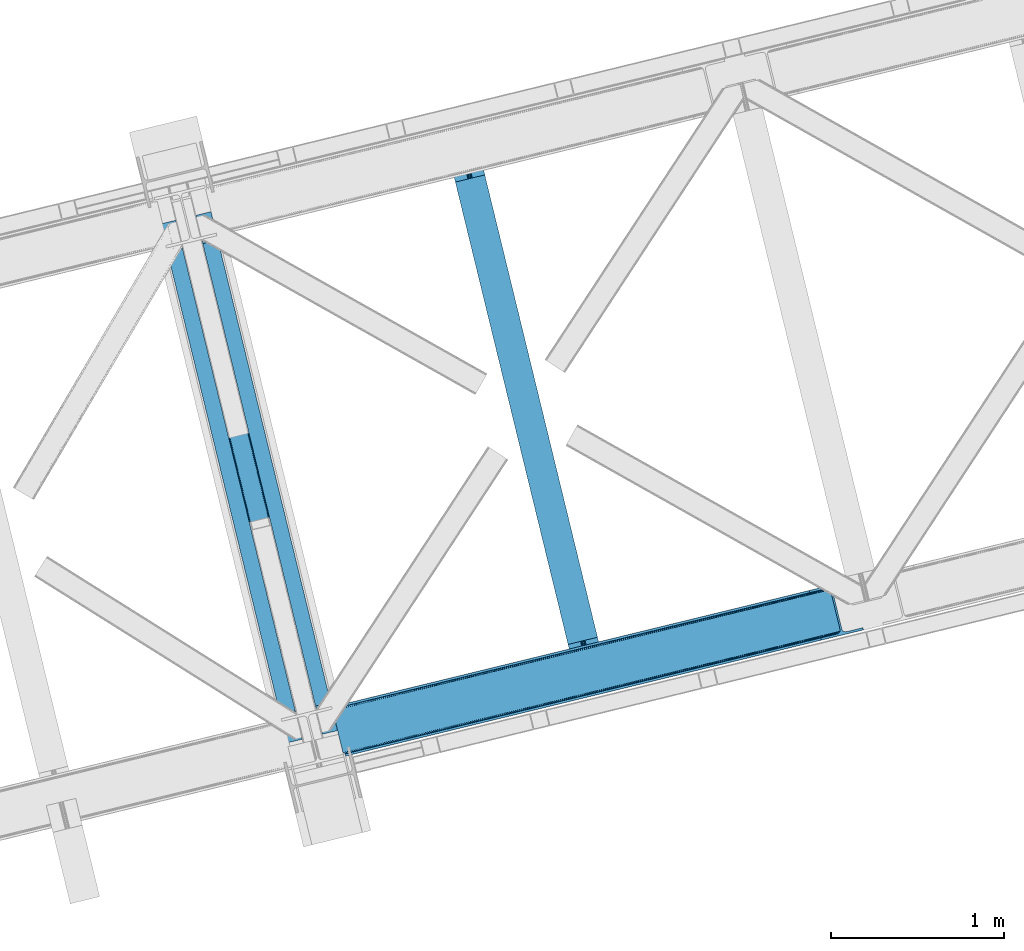
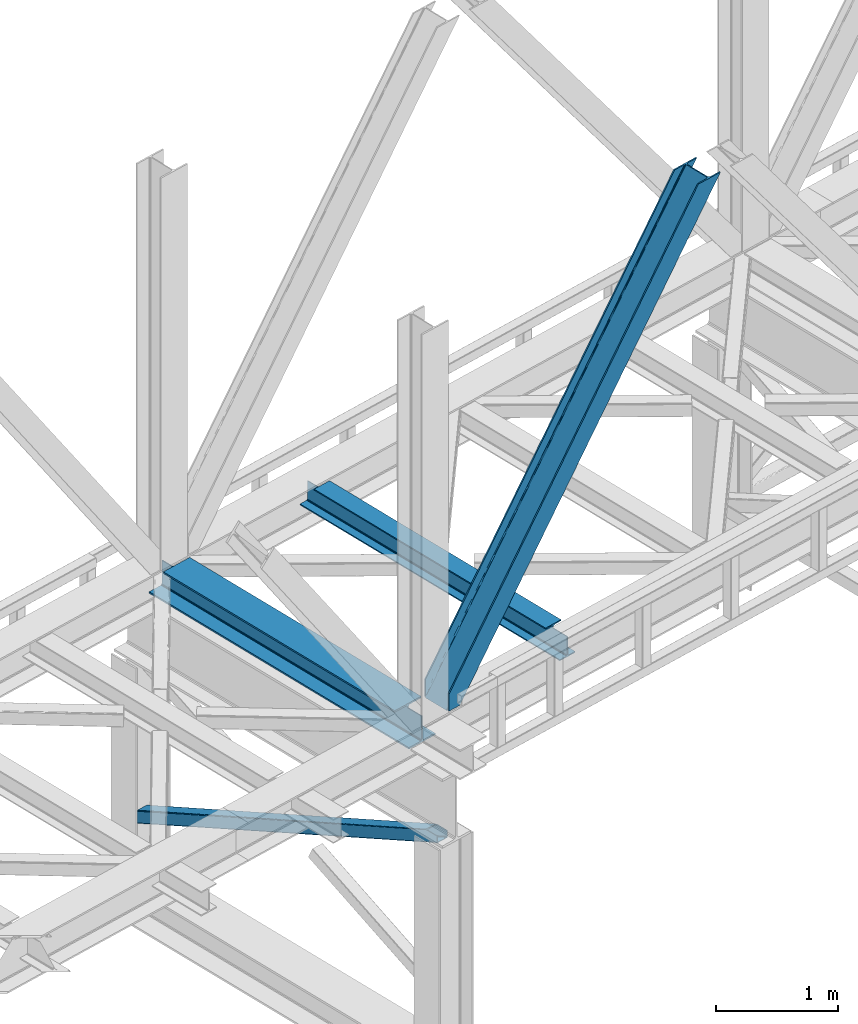
# One storey, part 37 of 93: 2 beams, 2 members.
"""IFC4 building model written with IfcOpenShell, lengths in millimetres."""

from ifc_helpers import new_model, entity, si_unit, converted_unit, derived_unit, direction, frame, origin, place, context, subcontext, project, spatial, triangles, polygons, material, type_object, element, save


model = new_model("IFC4")

# Units and contexts
model_context = context("Model", 3, precision=0.01, world=origin(), true_north=direction((6.12303176911189e-17, 1.0)))
plan_context = context("Plan", 3, precision=0.01, world=origin(), true_north=direction((6.12303176911189e-17, 1.0)))
body_context = subcontext(model_context, "Body", "Model", "MODEL_VIEW")
ifc_project = project(units=[si_unit("LENGTHUNIT", "METRE", prefix="MILLI"), si_unit("AREAUNIT", "SQUARE_METRE"), si_unit("VOLUMEUNIT", "CUBIC_METRE"), converted_unit("PLANEANGLEUNIT", "DEGREE", entity("IfcRatioMeasure", 0.0174532925199433), si_unit("PLANEANGLEUNIT", "RADIAN"), dimensions=[0, 0, 0, 0, 0, 0, 0]), si_unit("MASSUNIT", "GRAM", prefix="KILO"), derived_unit("MASSDENSITYUNIT", [(si_unit("MASSUNIT", "GRAM", prefix="KILO"), 1), (si_unit("LENGTHUNIT", "METRE"), -3)]), derived_unit("MOMENTOFINERTIAUNIT", [(si_unit("LENGTHUNIT", "METRE"), 4)]), si_unit("TIMEUNIT", "SECOND"), si_unit("FREQUENCYUNIT", "HERTZ"), si_unit("THERMODYNAMICTEMPERATUREUNIT", "DEGREE_CELSIUS"), derived_unit("THERMALTRANSMITTANCEUNIT", [(si_unit("MASSUNIT", "GRAM", prefix="KILO"), 1), (si_unit("THERMODYNAMICTEMPERATUREUNIT", "KELVIN"), -1), (si_unit("TIMEUNIT", "SECOND"), -3)]), derived_unit("VOLUMETRICFLOWRATEUNIT", [(si_unit("LENGTHUNIT", "METRE"), 3), (si_unit("TIMEUNIT", "SECOND"), -1)]), derived_unit("MASSFLOWRATEUNIT", [(si_unit("MASSUNIT", "GRAM", prefix="KILO"), 1), (si_unit("TIMEUNIT", "SECOND"), -1)]), derived_unit("ROTATIONALFREQUENCYUNIT", [(si_unit("TIMEUNIT", "SECOND"), -1)]), si_unit("ELECTRICCURRENTUNIT", "AMPERE"), si_unit("ELECTRICVOLTAGEUNIT", "VOLT"), si_unit("POWERUNIT", "WATT"), si_unit("FORCEUNIT", "NEWTON", prefix="KILO"), si_unit("ILLUMINANCEUNIT", "LUX"), si_unit("LUMINOUSFLUXUNIT", "LUMEN"), si_unit("LUMINOUSINTENSITYUNIT", "CANDELA"), derived_unit("USERDEFINED", [(si_unit("MASSUNIT", "GRAM", prefix="KILO"), -1), (si_unit("LENGTHUNIT", "METRE"), -2), (si_unit("TIMEUNIT", "SECOND"), 3), (si_unit("LUMINOUSFLUXUNIT", "LUMEN"), 1)]), derived_unit("LINEARVELOCITYUNIT", [(si_unit("LENGTHUNIT", "METRE"), 1), (si_unit("TIMEUNIT", "SECOND"), -1)]), si_unit("PRESSUREUNIT", "PASCAL"), derived_unit("USERDEFINED", [(si_unit("LENGTHUNIT", "METRE"), -2), (si_unit("MASSUNIT", "GRAM", prefix="KILO"), 1), (si_unit("TIMEUNIT", "SECOND"), -2)]), derived_unit("LINEARFORCEUNIT", [(si_unit("MASSUNIT", "GRAM", prefix="KILO"), 1), (si_unit("LENGTHUNIT", "METRE"), 1), (si_unit("TIMEUNIT", "SECOND"), -2), (si_unit("LENGTHUNIT", "METRE"), -1)]), derived_unit("PLANARFORCEUNIT", [(si_unit("MASSUNIT", "GRAM", prefix="KILO"), 1), (si_unit("LENGTHUNIT", "METRE"), 1), (si_unit("TIMEUNIT", "SECOND"), -2), (si_unit("LENGTHUNIT", "METRE"), -2)])], contexts=[model_context, plan_context])

# Site, building, storey
site_placement = place(None, origin())
site = spatial("IfcSite", under=ifc_project, at=site_placement, CompositionType="ELEMENT")
building_placement = place(site_placement, origin())
building = spatial("IfcBuilding", under=site, at=building_placement, CompositionType="ELEMENT")
storey_placement = place(building_placement, frame((0.0, 0.0, 15900.0)))
storey = spatial("IfcBuildingStorey", under=building, at=storey_placement, CompositionType="ELEMENT", Elevation=15900.0)

# Beams
ifc_material = material(Name="Metal painted (White)")
beam_type = type_object("IfcBeamType", PredefinedType="BEAM")
beam_1_placement = place(storey_placement, frame((-49495.314232944, 5721.698309528, 3385.0)))
element("IfcBeam", 1, at=beam_1_placement, inside=storey, type_object=beam_type, material=ifc_material, ObjectType="Steel Beam", PredefinedType="BEAM", context=body_context, shape_type="Tessellation", body=[
    polygons([(1022.42935345713, 71.0478278971021, 15.4999999999986), (1022.42935345713, 71.0478278971021, 0.0), (291.465617442446, 3069.74325535076, 0.0), (291.465617442455, 3069.74325535076, 15.4999999999986), (899.04224207317, 40.9709140873291, 15.4999999999986), (168.078506058491, 3039.66634154099, 15.4999999999986), (892.349898299208, 39.3395844888232, 16.8701684147963), (161.386162284528, 3038.03501194248, 16.8701684147963), (886.676403198592, 37.956610033653, 20.7720779386413), (155.712667183913, 3036.65203748731, 20.7720779386413), (882.885494970017, 37.0325360459173, 26.6116982174294), (151.921758955338, 3035.72796349958, 26.6116982174294), (881.554305026612, 36.708044413504, 33.500000000001), (150.590569011941, 3035.40347186716, 33.500000000001), (140.875048430522, 3033.03521093726, 33.500000000001), (140.875048430522, 3033.03521093726, 259.000000000002), (150.590569011932, 3035.40347186716, 259.000000000002), (0.0, 2998.69542745366, 0.0), (0.0, 2998.69542745366, 15.4999999999986), (123.387111383972, 3028.77234126343, 15.4999999999986), (130.079455157926, 3030.40367086194, 16.8701684147963), (135.752950258551, 3031.78664531711, 20.7720779386413), (139.543858487135, 3032.71071930484, 26.6116982174294), (881.554305026612, 36.708044413504, 259.000000000002), (871.838784445202, 34.3397834835992, 259.000000000002), (871.838784445202, 34.3397834836003, 33.500000000001), (870.507594501796, 34.0152918511837, 26.6116982174294), (866.716686273221, 33.0912178634492, 20.7720779386413), (861.043191172606, 31.7082434082778, 16.8701684147963), (854.350847398643, 30.076913809773, 15.4999999999986), (730.963736014679, 0.0, 15.4999999999986), (730.963736014679, 0.0, 0.0), (841.85453458624, 199.571930111231, 259.069791776412), (190.199733064572, 2872.911390143, 259.000000000002), (190.423126166413, 2871.99494573803, 259.61730333112), (190.435515010047, 2871.94412150426, 266.500003008253), (841.70935577274, 200.167408132525, 266.500002998871), (841.709705893492, 200.16597182779, 260.000004007589), (832.229597305445, 196.831858094285, 259.006343172366), (832.006227290721, 197.74830961273, 259.61730333112), (831.993838447078, 197.799133846505, 266.500003008253), (180.719997684385, 2869.57584721824, 266.500002998871), (180.719647563633, 2869.57728352297, 260.000004007589), (180.574841905298, 2870.17133233676, 259.07612046749), (180.484212483145, 2870.5431292131, 259.000000000002), (843.040843642667, 200.490677577209, 273.388305639783), (846.831120231363, 201.417342749122, 279.227924098781), (852.504191178902, 202.802057212798, 283.129832400615), (859.196382860027, 204.434010743612, 284.500000377228), (982.583411547871, 234.511263798724, 284.500000138971), (982.581741741219, 234.518113867455, 299.999995328161), (691.11631964394, 163.469484603412, 299.999995890962), (691.1179894506, 163.46263453468, 284.500000701776), (814.505018138444, 193.539887589791, 284.500000463519), (821.197505034583, 195.17063005637, 283.129832461069), (826.871416683352, 196.551895700895, 279.227924137322), (830.662951470335, 197.473399350194, 273.388305663684), (179.38850981445, 2869.25257777355, 273.388305639783), (175.598233225762, 2868.32591260164, 279.227924098781), (169.925162278224, 2866.94119813796, 283.129832400619), (163.232970597099, 2865.30924460715, 284.500000377228), (39.8459419092548, 2835.23199155204, 284.500000138971), (39.8476117159152, 2835.22514148331, 299.999995328161), (331.313033813185, 2906.27377074735, 299.999995890962), (331.311364006525, 2906.28062081608, 284.500000701776), (207.92433531869, 2876.20336776097, 284.500000463519), (201.231848422542, 2874.57262529439, 283.129832461065), (195.557936773782, 2873.19135964986, 279.227924137322), (191.76640198679, 2872.26985600057, 273.388305663684)], [[[1, 2, 3, 4]], [[5, 1, 4, 6]], [[7, 5, 6, 8]], [[9, 7, 8, 10]], [[11, 9, 10, 12]], [[13, 11, 12, 14]], [[15, 16, 17, 14, 12, 10, 8, 6, 4, 3, 18, 19, 20, 21, 22, 23]], [[13, 24, 25, 26, 27, 28, 29, 30, 31, 32, 2, 1, 5, 7, 9, 11]], [[2, 32, 18, 3]], [[32, 31, 19, 18]], [[31, 30, 20, 19]], [[27, 26, 15, 23]], [[28, 27, 23, 22]], [[29, 28, 22, 21]], [[30, 29, 21, 20]], [[33, 24, 13, 14, 17, 34, 35, 36, 37, 38]], [[25, 39, 40, 41, 42, 43, 44, 16, 15, 26]], [[39, 25, 24, 33]], [[45, 34, 17, 16]], [[41, 40, 38, 37, 46, 47, 48, 49, 50, 51, 52, 53, 54, 55, 56, 57]], [[42, 58, 59, 60, 61, 62, 63, 64, 65, 66, 67, 68, 69, 36, 35, 43]], [[46, 37, 36, 69]], [[47, 46, 69, 68]], [[48, 47, 68, 67]], [[49, 48, 67, 66]], [[50, 49, 66, 65]], [[51, 50, 65, 64]], [[52, 51, 64, 63]], [[53, 52, 63, 62]], [[54, 53, 62, 61]], [[55, 54, 61, 60]], [[56, 55, 60, 59]], [[57, 56, 59, 58]], [[41, 57, 58, 42]]], closed=False),
])
beam_2_placement = place(storey_placement, frame((-47831.5313333767, 6127.26299377395, 3441.0)))
element("IfcBeam", 2, at=beam_2_placement, inside=storey, type_object=beam_type, material=ifc_material, ObjectType="Steel Beam", PredefinedType="BEAM", context=body_context, shape_type="Tessellation", body=[
    polygons([(900.98534618944, 41.4445662733081, 11.000000000004), (900.98534618944, 41.4445662733081, 2.16573425859679e-12), (170.021610174761, 3040.13999372697, 2.16573425859679e-12), (170.021610174761, 3040.13999372697, 11.000000000004), (834.919806235823, 25.3403919499656, 11.000000000004), (103.956070221144, 3024.03581940362, 11.000000000004), (828.971056214531, 23.8903211957396, 12.2179274798217), (98.0073201998513, 3022.5857486494, 12.2179274798217), (823.927949458422, 22.6610105689183, 15.6862915010192), (92.9642134437427, 3021.35643802258, 15.6862915010192), (820.558253255246, 21.8396114687108, 20.8770650821657), (89.5945172405668, 3020.53503892237, 20.8770650821657), (819.37497330556, 21.5511744621195, 27.0000000000047), (88.4112372908809, 3020.24660191578, 27.0000000000047), (81.6103728838888, 3018.58881926485, 27.0000000000047), (81.6103728838888, 3018.58881926485, 203.000000000006), (88.4112372908809, 3020.24660191578, 203.000000000006), (8.66293703438714e-12, 2998.69542745366, 2.16573425859679e-12), (8.66293703438714e-12, 2998.69542745366, 10.9999999999997), (66.0655399536259, 3014.799601777, 11.000000000004), (72.014289974927, 3016.24967253123, 12.2179274798217), (77.057396731027, 3017.47898315805, 15.6862915010192), (80.4270929342029, 3018.30038225826, 20.8770650821657), (819.374973305552, 21.5511744621206, 203.000000000006), (812.574108898559, 19.8933918111876, 203.000000000006), (812.574108898559, 19.8933918111876, 27.0000000000047), (811.390828948873, 19.6049548045974, 20.8770650821657), (808.021132745698, 18.7835557043887, 15.6862915010192), (802.978025989598, 17.5542450775685, 12.2179274798217), (797.029275968296, 16.1041743233425, 11.000000000004), (730.963736014679, -1.08286712929839e-12, 10.9999999999997), (730.963736014679, -1.08286712929839e-12, 2.16573425859679e-12), (779.675212882757, 184.415062601693, 203.069791966819), (128.020401343512, 2857.75452019162, 203.000000000006), (128.243282132658, 2856.84017775719, 203.617301946336), (128.256196377177, 2856.7871977843, 217.000003693143), (779.530009633833, 185.010597404072, 217.000003676718), (779.530880241731, 185.007025963192, 204.00000679514), (772.96491171832, 182.385463974442, 203.006342981529), (772.742064056782, 183.299815969774, 203.617301946336), (772.729149812263, 183.352795942667, 217.000003693143), (121.455336555608, 2855.1293963229, 217.000003676718), (121.45446594771, 2855.13296776378, 204.00000679514), (121.310166358664, 2855.72494066435, 203.076120467494), (121.21953693652, 2856.09673754069, 203.000000000006), (780.713494357868, 185.298194377513, 223.122939328039), (784.082490766547, 186.122464201392, 228.313710402595), (789.125126170571, 187.353708426697, 231.782072735464), (795.073705041275, 188.80448128138, 232.999999602236), (861.13915590679, 204.909021065315, 232.999999283132), (861.137682570361, 204.915065042187, 243.999994005812), (691.11630166644, 163.469558245297, 243.999994827032), (691.117775002877, 163.463514268423, 233.000000104353), (757.183225868401, 179.568054052358, 232.999999785253), (763.132130996731, 181.017488520583, 231.782072861016), (768.17569550387, 182.244921343717, 228.313710479427), (771.546082413602, 183.063487001148, 223.12293937232), (120.271851831572, 2854.84179934945, 223.122939328039), (116.902855422893, 2854.01752952557, 228.313710402595), (111.860220018869, 2852.78628530027, 231.782072735464), (105.911641148165, 2851.33551244559, 232.999999602236), (39.8461902826505, 2835.23097266165, 232.999999283128), (39.8476636190881, 2835.22492868478, 243.999994005812), (209.869044523001, 2876.67043548167, 243.999994827032), (209.867571186563, 2876.67647945854, 233.000000104357), (143.80212032104, 2860.57193967461, 232.999999785253), (137.85321519271, 2859.12250520638, 231.782072861012), (132.809650685579, 2857.89507238325, 228.313710479427), (129.439263775838, 2857.07650672582, 223.12293937232)], [[[1, 2, 3, 4]], [[5, 1, 4, 6]], [[7, 5, 6, 8]], [[9, 7, 8, 10]], [[11, 9, 10, 12]], [[13, 11, 12, 14]], [[15, 16, 17, 14, 12, 10, 8, 6, 4, 3, 18, 19, 20, 21, 22, 23]], [[13, 24, 25, 26, 27, 28, 29, 30, 31, 32, 2, 1, 5, 7, 9, 11]], [[2, 32, 18, 3]], [[32, 31, 19, 18]], [[31, 30, 20, 19]], [[27, 26, 15, 23]], [[28, 27, 23, 22]], [[29, 28, 22, 21]], [[30, 29, 21, 20]], [[33, 24, 13, 14, 17, 34, 35, 36, 37, 38]], [[25, 39, 40, 41, 42, 43, 44, 16, 15, 26]], [[39, 25, 24, 33]], [[45, 34, 17, 16]], [[41, 40, 38, 37, 46, 47, 48, 49, 50, 51, 52, 53, 54, 55, 56, 57]], [[42, 58, 59, 60, 61, 62, 63, 64, 65, 66, 67, 68, 69, 36, 35, 43]], [[46, 37, 36, 69]], [[47, 46, 69, 68]], [[48, 47, 68, 67]], [[49, 48, 67, 66]], [[50, 49, 66, 65]], [[51, 50, 65, 64]], [[52, 51, 64, 63]], [[53, 52, 63, 62]], [[54, 53, 62, 61]], [[55, 54, 61, 60]], [[56, 55, 60, 59]], [[57, 56, 59, 58]], [[41, 57, 58, 42]]], closed=False),
])

# Members
member_type_1 = type_object("IfcMemberType", PredefinedType="BRACE")
member_1_placement = place(storey_placement, frame((-48501.6906738281, 5645.25251312256, 3694.99929199219)))
element("IfcMember", 3, at=member_1_placement, inside=storey, type_object=member_type_1, ObjectType="Steel Vertical Brace", PredefinedType="BRACE", context=body_context, shape_type="Tessellation", body=[
    triangles([(58.5313110351563, 27.8802749633796, 0.0), (60.4474731445298, 20.0011047363287, 0.0), (59.0987182617173, 20.928955078125, 0.827856445310317), (58.9684936523408, 19.7534454345705, 1.13248901367115), (72.2095458984331, 11.6585906982427, 0.0), (71.3956420898394, 13.9003143310547, 30.563250732419), (70.228271484375, 15.4356857299808, 25.1542785644524), (72.2095458984331, 11.6585906982427, 171.175598144531), (71.9304931640581, 12.6195785522468, 42.2602111816377), (71.9304931640581, 12.6195785522468, 171.115136718749), (70.3910522460938, 15.5600967407227, 0.0), (68.8190551757798, 17.2873168945316, 18.6337463378877), (67.2145019531235, 18.4651519775398, 14.6921264648408), (63.168237304686, 19.9295974731449, 7.29955444335792), (63.168237304686, 19.9295974731449, 0.0), (67.2145019531235, 18.4651519775398, 0.0), (2821.28360595703, 682.803089904785, 3911.00081176758), (2916.00805664063, 705.89354095459, 3911.00081176758), (2933.63488769531, 721.628045654297, 3911.00081176758), (2930.26765136718, 714.795904541016, 3911.00081176758), (2933.67209472656, 728.727030944825, 3911.00081176758), (2924.07733154297, 709.270660400391, 3911.00081176758), (2824.35783691406, 670.173046875, 3911.00081176758), (75.0512329101548, 0.0, 171.175598144531), (75.0512329101548, 0.0, 0.0), (192.881249999999, 28.7226654052738, 0.0), (3068.02668457031, 729.569421386719, 3911.00081176758), (3064.94780273437, 742.199464416504, 3911.00081176758), (189.802368164063, 41.352708435059, 0.0), (2970.22335205078, 719.109594726563, 3911.00081176758), (95.0779174804702, 18.2622573852541, 0.0), (2961.50760498047, 718.394522094727, 3911.00081176758), (86.3621704101533, 17.5477661132818, 0.0), (2953.46623535156, 720.451373291016, 3911.00081176758), (78.32080078125, 19.6040359497074, 0.0), (2947.33172607422, 724.966213989258, 3911.00081176758), (72.1862915039019, 24.1188766479499, 0.0), (2944.02960205078, 731.251295471192, 3911.00081176758), (68.8841674804644, 30.4045394897466, 0.0), (2888.85157470703, 957.622943115235, 3911.00081176758), (13.7061401367173, 256.77618713379, 0.0), (2888.88878173828, 964.722509765626, 3911.00081176758), (13.7433471679688, 263.875172424317, 0.0), (2892.25601806641, 971.554650878907, 3911.00081176758), (17.115234375, 270.707313537598, 0.0), (2898.44633789062, 977.079895019531, 3911.00081176758), (23.3055541992144, 276.232557678223, 0.0), (2906.51561279297, 980.457014465333, 3911.00081176758), (31.3701782226563, 279.609677124024, 0.0), (3001.24471435547, 1003.54688415527, 3911.00081176758), (126.099279785158, 302.700128173828, 0.0), (2998.16583251953, 1016.17750854492, 3911.00081176758), (123.020397949214, 315.330171203614, 0.0), (2878.49406738281, 955.098678588867, 3911.00081176758), (3.3486328125, 254.251922607422, 0.0), (2869.05743408203, 965.899182128906, 3911.00081176758), (2861.01606445312, 967.955451965332, 3911.00081176758), (2754.49698486328, 956.78055267334, 3911.00081176758), (2852.30031738281, 967.24096069336, 3911.00081176758), (2757.57586669922, 944.150509643555, 3911.00081176758), (2875.19194335937, 961.384341430665, 3911.00081176758), (5.18572998046875, 286.60750579834, 171.175598144531), (5.18572998046875, 286.60750579834, 0.0), (8.02741699218313, 274.948915100098, 171.175598144531), (8.22275390625146, 273.966998291016, 171.115136718749), (8.22275390625146, 273.966998291016, 42.2602111816377), (8.02741699218313, 274.948915100098, 0.0), (3.80906982421584, 263.445547485352, 0.0), (6.72982177734229, 266.608145141602, 0.0), (8.21345214843313, 270.64917755127, 0.0), (1.42781982421729, 262.13051147461, 0.0), (3.80906982421584, 263.445547485352, 7.29955444335792), (8.33902587890771, 272.585105895996, 30.563250732419), (8.21345214843313, 270.64917755127, 24.1799194335908), (7.30653076171438, 268.181886291504, 18.3872497558586), (6.72982177734229, 266.608145141602, 14.6921264648408), (0.0, 261.670074462891, 1.13248901367115), (0.655773925776884, 260.685250854493, 0.827856445310317)], [[1, 2, 3], [4, 3, 2], [5, 6, 7], [5, 8, 9], [10, 9, 8], [9, 6, 5], [11, 12, 13], [11, 7, 12], [14, 4, 2], [2, 15, 14], [16, 13, 14], [14, 15, 16], [13, 16, 11], [7, 11, 5], [17, 18, 10], [9, 10, 18], [19, 3, 14], [14, 20, 19], [14, 13, 20], [13, 12, 20], [3, 4, 14], [19, 21, 1], [1, 3, 19], [6, 20, 7], [6, 22, 20], [12, 7, 20], [18, 22, 9], [6, 9, 22], [8, 17, 10], [23, 8, 24], [8, 23, 17], [25, 24, 5], [8, 5, 24], [23, 26, 27], [26, 23, 24], [25, 26, 24], [28, 27, 29], [26, 29, 27], [30, 28, 29], [29, 31, 30], [32, 30, 31], [31, 33, 32], [34, 32, 33], [33, 35, 34], [36, 34, 35], [35, 37, 36], [38, 36, 37], [37, 39, 38], [40, 38, 39], [39, 41, 40], [42, 40, 43], [41, 43, 40], [44, 42, 45], [43, 45, 42], [46, 44, 47], [45, 47, 44], [48, 46, 49], [47, 49, 46], [50, 48, 51], [49, 51, 48], [52, 50, 53], [51, 53, 50], [21, 54, 55], [55, 1, 21], [54, 21, 40], [20, 22, 32], [18, 23, 27], [17, 23, 18], [22, 18, 30], [21, 19, 36], [19, 20, 34], [56, 46, 57], [58, 59, 52], [59, 57, 48], [58, 60, 59], [56, 61, 44], [61, 54, 42], [40, 21, 38], [30, 32, 22], [36, 19, 34], [32, 34, 20], [36, 38, 21], [27, 30, 18], [27, 28, 30], [48, 57, 46], [44, 61, 42], [40, 42, 54], [44, 46, 56], [48, 52, 59], [52, 48, 50], [58, 53, 62], [58, 52, 53], [53, 63, 62], [64, 58, 62], [60, 64, 65], [64, 60, 58], [59, 60, 65], [65, 66, 59], [67, 64, 62], [62, 63, 67], [11, 35, 5], [68, 41, 55], [69, 70, 43], [69, 43, 68], [55, 71, 68], [67, 63, 47], [67, 45, 70], [55, 39, 1], [37, 16, 15], [2, 1, 15], [15, 1, 39], [11, 16, 37], [25, 5, 33], [39, 55, 41], [49, 47, 63], [43, 70, 45], [47, 45, 67], [43, 41, 68], [53, 49, 63], [53, 51, 49], [31, 25, 33], [35, 11, 37], [39, 37, 15], [35, 33, 5], [31, 26, 25], [26, 31, 29], [72, 68, 71], [67, 73, 66], [67, 70, 74], [74, 73, 67], [64, 67, 66], [66, 65, 64], [75, 70, 76], [75, 74, 70], [69, 76, 70], [76, 69, 72], [68, 72, 69], [71, 77, 72], [78, 61, 72], [61, 56, 75], [75, 76, 61], [76, 72, 61], [56, 57, 73], [73, 74, 56], [57, 59, 66], [66, 73, 57], [74, 75, 56], [72, 77, 78], [54, 61, 55], [78, 55, 61], [71, 55, 78], [78, 77, 71]]),
])
member_type_2 = type_object("IfcMemberType", PredefinedType="BRACE")
member_2_placement = place(storey_placement, frame((-49464.9481567383, 5508.86839599609, 911.279672241211)))
element("IfcMember", 4, at=member_2_placement, inside=storey, type_object=member_type_2, ObjectType="Steel Vertical Brace", PredefinedType="BRACE", context=body_context, shape_type="Tessellation", body=[
    triangles([(109.783996582031, 3493.74488525391, 0.0), (954.899853515628, 26.761738586426, 1610.78191223144), (6.79958496093604, 3468.64118499756, 0.0), (851.915441894533, 1.65803833007885, 1610.78191223144), (112.188500976561, 3494.3308959961, 1.12551269531104), (957.304357910158, 27.3477493286136, 1611.90626220703), (114.593005371091, 3494.91748809815, 2.24986267089844), (959.708862304688, 27.9337600708013, 1613.03061218261), (115.588293457033, 3495.15991516113, 4.96481323242188), (960.704150390622, 28.1761871337894, 1615.74672546387), (116.583581542967, 3495.40292358399, 7.68092651366896), (961.699438476564, 28.4191955566412, 1618.46167602539), (0.99528808593459, 3467.22615509033, 4.96481323242188), (846.106494140622, 0.243008422851744, 1615.74672546387), (0.0, 3466.98372802735, 7.68092651366896), (845.111206054688, 0.0, 1618.46167602539), (1.99057617187646, 3467.46916351318, 2.24986267089844), (847.106433105466, 0.486016845703489, 1613.03061218261), (4.39508056640625, 3468.05575561524, 1.12551269531104), (849.510937500003, 1.07202758789117, 1611.90626220703), (933.347680664061, 144.732444763184, 1680.7206665039), (116.583581542967, 3495.40292358399, 123.979641723632), (961.699438476564, 28.4191955566412, 1680.7206665039), (816.759448242185, 116.313830566407, 1680.7206665039), (0.0, 3466.98372802735, 123.979641723632), (845.111206054688, 0.0, 1680.7206665039), (112.188500976561, 3494.3308959961, 130.53505554199), (109.783996582031, 3493.74488525391, 131.659405517577), (922.515783691408, 159.605374145508, 1680.7206665039), (114.593005371091, 3494.91748809815, 129.409542846679), (925.427233886716, 158.981575012207, 1680.7206665039), (115.588293457033, 3495.15991516113, 126.694592285156), (928.506115722659, 155.935830688477, 1680.7206665039), (931.287341308591, 150.932647705078, 1680.7206665039), (6.79958496093604, 3468.64118499756, 131.659405517577), (819.531372070313, 134.501673889161, 1680.7206665039), (815.73625488281, 122.765762329102, 1680.7206665039), (0.99528808593459, 3467.22615509033, 126.694592285156), (815.903686523438, 128.488087463379, 1680.7206665039), (1.99057617187646, 3467.46916351318, 129.409542846679), (817.233837890628, 132.608766174317, 1680.7206665039), (4.39508056640625, 3468.05575561524, 130.53505554199), (923.445959472658, 145.989926147461, 1680.7206665039), (926.524841308594, 142.944181823731, 1680.7206665039), (920.534509277342, 146.613725280762, 1680.7206665039), (931.366406250003, 131.741377258301, 1680.7206665039), (956.839270019533, 27.2349655151374, 1680.7206665039), (929.306066894533, 137.940998840332, 1680.7206665039), (823.638098144533, 117.864317321778, 1680.7206665039), (824.972900390625, 121.986158752442, 1680.7206665039), (827.265783691408, 123.878485107422, 1680.7206665039), (824.49385986328, 105.690641784669, 1680.7206665039), (823.470666503905, 112.142573547364, 1680.7206665039), (849.971374511719, 1.18423004150463, 1680.7206665039), (111.728063964845, 3494.21869354248, 118.492767333984), (110.732775878903, 3493.97568511963, 121.208880615231), (109.73283691406, 3493.73325805664, 123.923831176755), (107.332983398439, 3493.14724731445, 125.048181152342), (104.923828125, 3492.5606552124, 126.173693847653), (11.6551025390654, 3469.82541503906, 126.173693847653), (9.25059814452834, 3469.23940429688, 125.048181152342), (6.84609374999854, 3468.65339355469, 123.923831176755), (5.85080566406396, 3468.4109664917, 121.208880615231), (4.85551757812209, 3468.16795806885, 118.492767333984), (111.728063964845, 3494.21869354248, 13.166638183593), (956.839270019533, 27.2349655151374, 1623.94738769531), (4.85551757812209, 3468.16795806885, 13.166638183593), (849.971374511719, 1.18423004150463, 1623.94738769531), (109.73283691406, 3493.73325805664, 7.73557434081886), (107.332983398439, 3493.14724731445, 6.61122436523146), (110.732775878903, 3493.97568511963, 10.4505249023423), (104.923828125, 3492.5606552124, 5.48571166992042), (6.84609374999854, 3468.65339355469, 7.73557434081886), (5.85080566406396, 3468.4109664917, 10.4505249023423), (9.25059814452834, 3469.23940429688, 6.61122436523146), (11.6551025390654, 3469.82541503906, 5.48571166992042), (950.039685058597, 25.5775085449222, 1616.26762390137), (952.444189453126, 26.1635192871099, 1617.39197387695), (954.848693847656, 26.7495300292976, 1618.51748657227), (856.770959472655, 2.84226837158258, 1616.26762390137), (854.366455078125, 2.2562576293949, 1617.39197387695), (851.961950683595, 1.66966552734448, 1618.51748657227), (955.843981933591, 26.9925384521484, 1621.23243713379), (850.966662597653, 1.42723846435547, 1621.23243713379)], [[1, 2, 3], [4, 3, 2], [5, 6, 2], [2, 1, 5], [7, 8, 6], [6, 5, 7], [9, 10, 8], [8, 7, 9], [11, 12, 10], [10, 9, 11], [13, 14, 15], [16, 15, 14], [17, 18, 13], [14, 13, 18], [19, 20, 17], [18, 17, 20], [3, 4, 19], [20, 19, 4], [11, 21, 12], [21, 11, 22], [23, 12, 21], [24, 15, 16], [24, 25, 15], [16, 26, 24], [27, 28, 29], [30, 27, 31], [32, 30, 33], [22, 32, 34], [34, 21, 22], [33, 34, 32], [31, 33, 30], [29, 31, 27], [29, 28, 35], [35, 36, 29], [25, 24, 37], [38, 37, 39], [40, 39, 41], [42, 41, 36], [36, 35, 42], [41, 42, 40], [39, 40, 38], [37, 38, 25], [43, 44, 34], [33, 43, 34], [29, 33, 31], [45, 29, 36], [33, 45, 43], [29, 45, 33], [44, 21, 34], [23, 46, 47], [23, 21, 46], [44, 48, 21], [48, 46, 21], [37, 49, 50], [36, 51, 45], [51, 39, 50], [39, 51, 36], [50, 39, 37], [39, 36, 41], [24, 49, 37], [52, 53, 24], [53, 49, 24], [52, 26, 54], [24, 26, 52], [55, 46, 48], [56, 48, 44], [57, 44, 43], [58, 43, 45], [45, 59, 58], [43, 58, 57], [44, 57, 56], [48, 56, 55], [59, 45, 51], [51, 60, 59], [61, 60, 51], [62, 61, 50], [63, 62, 49], [64, 63, 53], [53, 52, 64], [49, 53, 63], [50, 49, 62], [51, 50, 61], [46, 65, 66], [46, 55, 65], [66, 47, 46], [67, 52, 68], [52, 67, 64], [54, 68, 52], [58, 59, 28], [32, 57, 27], [32, 27, 30], [28, 59, 35], [28, 27, 58], [57, 58, 27], [55, 22, 11], [22, 56, 57], [55, 56, 22], [22, 57, 32], [42, 62, 38], [60, 35, 59], [61, 42, 35], [61, 35, 60], [38, 40, 42], [62, 25, 38], [42, 61, 62], [62, 63, 25], [25, 64, 15], [64, 25, 63], [69, 5, 70], [11, 65, 55], [71, 11, 69], [11, 71, 65], [69, 11, 9], [70, 1, 72], [69, 9, 5], [5, 9, 7], [72, 1, 3], [5, 1, 70], [73, 13, 15], [74, 73, 15], [75, 19, 73], [67, 15, 64], [15, 67, 74], [19, 13, 73], [3, 76, 72], [19, 75, 3], [76, 3, 75], [17, 13, 19], [77, 4, 2], [2, 6, 78], [6, 8, 10], [6, 79, 78], [2, 78, 77], [79, 6, 10], [80, 4, 77], [18, 20, 14], [20, 4, 81], [81, 82, 20], [20, 82, 14], [80, 81, 4], [14, 82, 16], [83, 12, 66], [10, 12, 79], [83, 79, 12], [23, 66, 12], [23, 47, 66], [16, 84, 68], [84, 16, 82], [68, 26, 16], [26, 68, 54], [77, 72, 76], [76, 80, 77], [66, 65, 83], [71, 83, 65], [83, 71, 79], [69, 79, 71], [79, 69, 78], [70, 78, 69], [78, 70, 77], [72, 77, 70], [80, 76, 75], [75, 81, 80], [81, 75, 73], [73, 82, 81], [82, 73, 74], [74, 84, 82], [84, 74, 67], [67, 68, 84]]),
])

save(model, "model.ifc")
